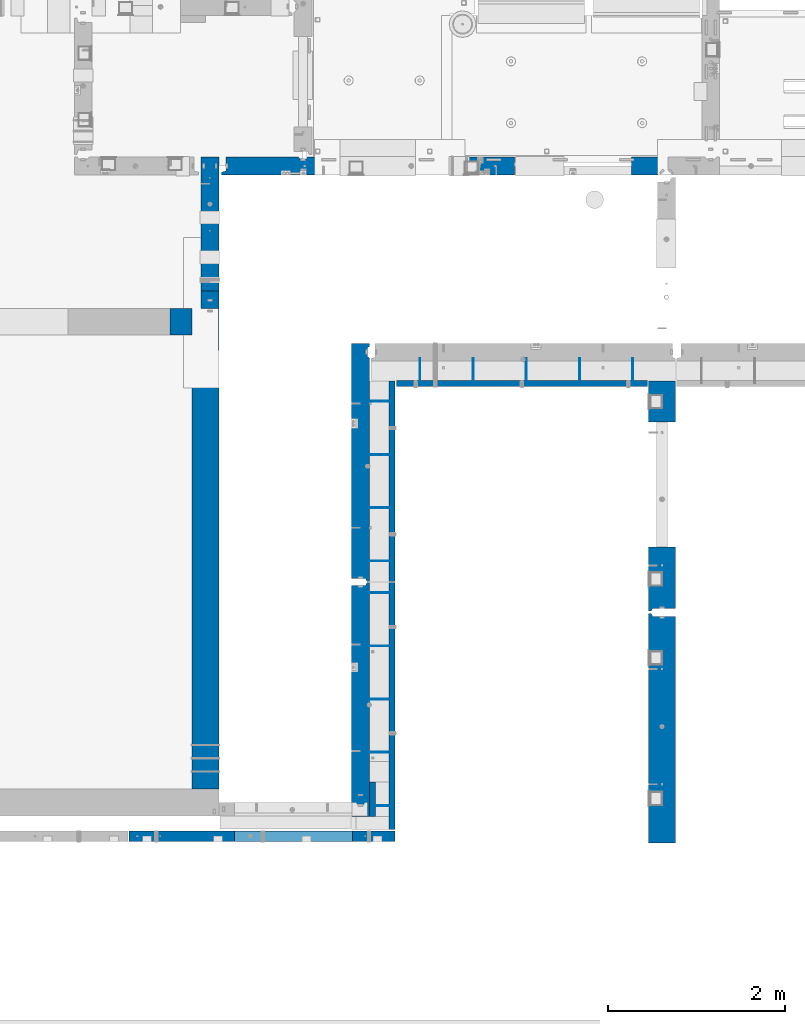
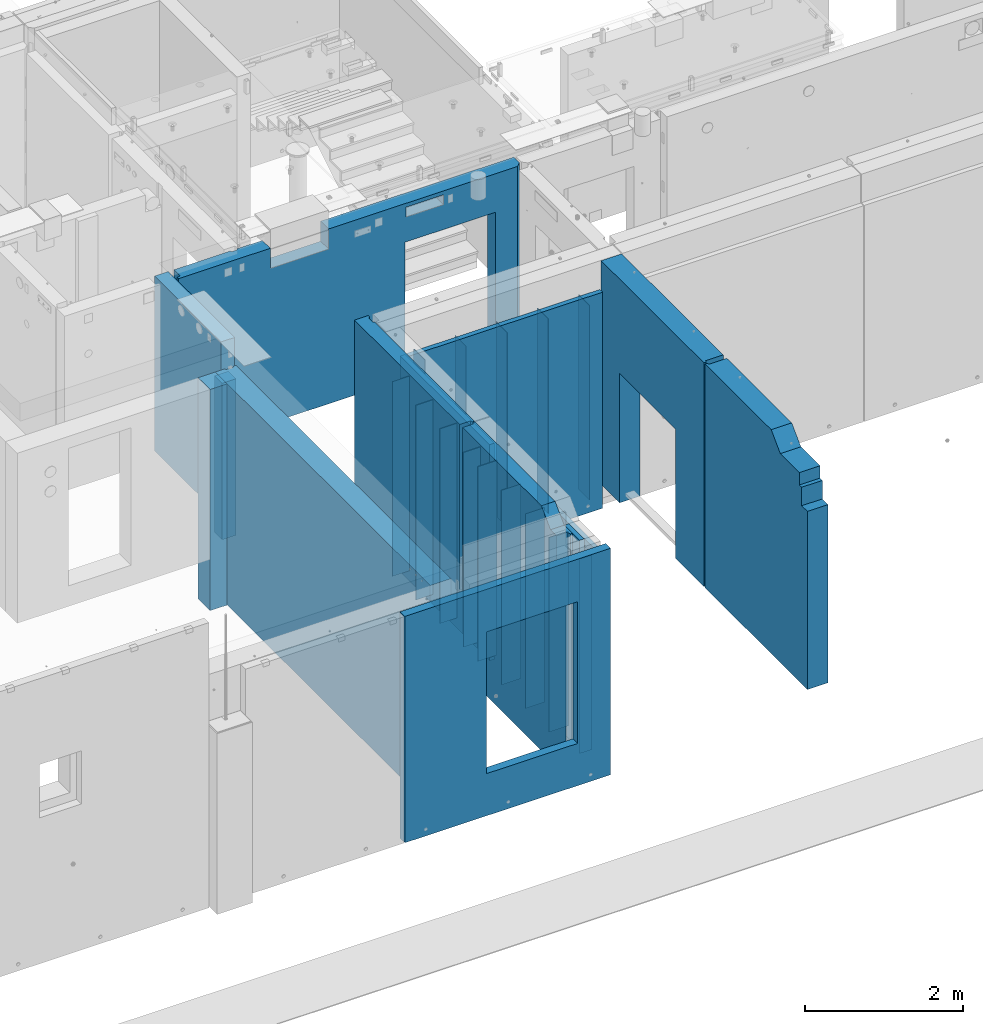
# One storey, part 171 of 264: 28 walls, 9 elements without a shape of their own.
"""IFC2X3 building model written with IfcOpenShell, lengths in millimetres."""

import ifcopenshell
import ifcopenshell.guid

model = None  # the IFC model being written
_history = None  # IfcOwnerHistory: only IFC2X3 demands one
_inside = {}  # id of a spatial element -> (the spatial element, [elements in it])
_under = {}  # id of a project, library or spatial element -> (it, [spatial elements below it])
_declared = {}  # id of a project -> (the project, [libraries it declares])
_typed = {}  # id of a type object -> (the type object, [elements of that type])
_made_of = {}  # id of a material, layer set ... -> (it, [elements and type objects made of it])


def new_model(schema):
    """Start an empty IFC model of exactly this schema.

    Asked for "IFC4X3", IfcOpenShell would pick the latest addendum, in which some entities
    have other attributes; the version numbers below select the first issue.
    IFC2X3 requires an IfcOwnerHistory on every rooted entity: one is made here for all.
    """
    global model, _history
    if schema == "IFC4X3":
        model = ifcopenshell.file(schema_version=(4, 3, 0, 0))
    else:
        model = ifcopenshell.file(schema=schema)
    _inside.clear()
    _under.clear()
    _declared.clear()
    _typed.clear()
    _made_of.clear()
    _history = None
    if model.schema == "IFC2X3":
        org = make("IfcOrganization", Name="unknown")
        user = make(
            "IfcPersonAndOrganization",
            ThePerson=make("IfcPerson", FamilyName="unknown"),
            TheOrganization=org,
        )
        app = make(
            "IfcApplication",
            ApplicationDeveloper=org,
            Version="unknown",
            ApplicationFullName="unknown",
            ApplicationIdentifier="unknown",
        )
        _history = make(
            "IfcOwnerHistory",
            OwningUser=user,
            OwningApplication=app,
            ChangeAction="ADDED",
            CreationDate=0,
        )
    return model


def make(cls, **values):
    """One entity of the class cls with the attributes given. An attribute that is None is left unset."""
    return model.create_entity(
        cls, **{name: value for name, value in values.items() if value is not None}
    )


def rooted(cls, **values):
    """An entity with a GlobalId (a new one), such as an element, a storey or a relation."""
    return make(cls, GlobalId=ifcopenshell.guid.new(), OwnerHistory=_history, **values)


def si_unit(unit_type, name, prefix=None):
    """IfcSIUnit, for example si_unit("LENGTHUNIT", "METRE", prefix="MILLI")."""
    return make("IfcSIUnit", UnitType=unit_type, Prefix=prefix, Name=name)


def assignment(units):
    """IfcUnitAssignment: the units of a project."""
    return None if units is None else make("IfcUnitAssignment", Units=units)


def point(xyz):
    """IfcCartesianPoint."""
    return None if xyz is None else make("IfcCartesianPoint", Coordinates=xyz)


def direction(xyz):
    """IfcDirection."""
    return None if xyz is None else make("IfcDirection", DirectionRatios=xyz)


def frame(location, z_axis=None, x_axis=None):
    """IfcAxis2Placement3D, a coordinate frame: its origin and axes. An axis left out is left unset."""
    return make(
        "IfcAxis2Placement3D",
        Location=point(location),
        Axis=direction(z_axis),
        RefDirection=direction(x_axis),
    )


def origin_with_axes():
    """The frame at (0, 0, 0) with the z axis (0, 0, 1) and the x axis (1, 0, 0) written out."""
    return frame((0.0, 0.0, 0.0), z_axis=(0.0, 0.0, 1.0), x_axis=(1.0, 0.0, 0.0))


def place(relative_to, where):
    """IfcLocalPlacement: puts the frame where relative to a parent placement (None: the world)."""
    return make(
        "IfcLocalPlacement", PlacementRelTo=relative_to, RelativePlacement=where
    )


def context(
    kind, dimensions, precision=None, world=None, true_north=None, identifier=None
):
    """IfcGeometricRepresentationContext, for example the 3D "Model" context."""
    return make(
        "IfcGeometricRepresentationContext",
        ContextIdentifier=identifier,
        ContextType=kind,
        CoordinateSpaceDimension=dimensions,
        Precision=precision,
        WorldCoordinateSystem=world,
        TrueNorth=true_north,
    )


def subcontext(parent, identifier, kind, view, scale=None):
    """IfcGeometricRepresentationSubContext, for example "Body" below "Model"."""
    return make(
        "IfcGeometricRepresentationSubContext",
        ContextIdentifier=identifier,
        ContextType=kind,
        ParentContext=parent,
        TargetScale=scale,
        TargetView=view,
    )


def project(units=None, contexts=None):
    """IfcProject with its units and contexts."""
    return rooted(
        "IfcProject",
        Name="project",
        RepresentationContexts=contexts,
        UnitsInContext=assignment(units),
    )


def spatial(cls, under=None, at=None, **own):
    """A site, building, storey or space (cls), placed at a placement, below another one or the project."""
    s = rooted(cls, ObjectPlacement=at, **own)
    if under is not None:
        _under.setdefault(under.id(), (under, []))[1].append(s)
    return s


def faces_of(points, faces, orient=None, outer=None):
    """IfcFace entities. A face is a list of loops; a loop is a list of indices into points, from 0.

    orient and outer hold one flag for each loop. By default every Orientation is true, the
    first loop of a face is its IfcFaceOuterBound and the others are IfcFaceBound.
    """
    made = []
    for i, loops in enumerate(faces):
        bounds = []
        for j, loop in enumerate(loops):
            is_outer = j == 0 if outer is None else outer[i][j]
            bounds.append(
                make(
                    "IfcFaceOuterBound" if is_outer else "IfcFaceBound",
                    Bound=make("IfcPolyLoop", Polygon=[points[k] for k in loop]),
                    Orientation=True if orient is None else orient[i][j],
                )
            )
        made.append(make("IfcFace", Bounds=bounds))
    return made


def faceted_brep(points, faces, orient=None, outer=None, voids=None):
    """IfcFacetedBrep: a solid bounded by flat faces; with voids (closed shells), ...WithVoids."""
    shared = [point(p) for p in points]
    hull = make("IfcClosedShell", CfsFaces=faces_of(shared, faces, orient, outer))
    if voids is None:
        return make("IfcFacetedBrep", Outer=hull)
    return make(
        "IfcFacetedBrepWithVoids",
        Outer=hull,
        Voids=[
            make(cls, CfsFaces=faces_of(shared, fs, o, b)) for cls, fs, o, b in voids
        ],
    )


def shape(context_of_items, identifier, shape_type, items):
    """IfcShapeRepresentation: the items that make up one representation, for example the "Body"."""
    return make(
        "IfcShapeRepresentation",
        ContextOfItems=context_of_items,
        RepresentationIdentifier=identifier,
        RepresentationType=shape_type,
        Items=items,
    )


def material(Name=None, Category=None):
    """IfcMaterial."""
    return make("IfcMaterial", Name=Name, Category=Category)


def made_of(thing, what):
    """Note that an element or type object is made of a material, layer set ...; save() writes the relation."""
    if what is not None:
        _made_of.setdefault(what.id(), (what, []))[1].append(thing)
    return thing


def type_object(cls, material=None, **own):
    """A type object (cls), such as IfcWallType, which elements share."""
    return made_of(rooted(cls, **own), material)


def element(
    cls,
    number,
    at=None,
    inside=None,
    cuts=None,
    type_object=None,
    material=None,
    context=None,
    identifier="Body",
    shape_type=None,
    held_by="IfcProductDefinitionShape",
    body=None,
    shapes=None,
    **own,
):
    """One element of the class cls, such as IfcWall. Its Tag is "e" and its number.

    at: its placement. inside: the storey or other place that contains it. cuts: it is an
    opening in that element (IfcRelVoidsElement). A single representation is given by context,
    identifier, shape_type and body (its items); several are given by shapes. held_by: the class
    of the entity that holds the representations. save() writes the other relations.
    """
    e = rooted(cls, Tag="e%d" % number, ObjectPlacement=at, **own)
    if body is not None:
        shapes = [shape(context, identifier, shape_type, body)]
    if shapes is not None:
        e.Representation = make(held_by, Representations=shapes)
    if inside is not None:
        _inside.setdefault(inside.id(), (inside, []))[1].append(e)
    if cuts is not None:
        rooted(
            "IfcRelVoidsElement", RelatingBuildingElement=cuts, RelatedOpeningElement=e
        )
    if type_object is not None:
        _typed.setdefault(type_object.id(), (type_object, []))[1].append(e)
    return made_of(e, material)


def aggregate(whole, parts):
    """IfcRelAggregates: a whole, such as a stair, and the parts it consists of."""
    return rooted("IfcRelAggregates", RelatingObject=whole, RelatedObjects=parts)


def save(model, path):
    """Write the relations noted so far, then the file.

    IfcRelAggregates (storeys below a building ...), IfcRelContainedInSpatialStructure (elements
    in a storey), IfcRelDefinesByType, IfcRelAssociatesMaterial and IfcRelDeclares: one each for
    every whole, place, type object, material and project.
    """
    for whole, parts in _under.values():
        aggregate(whole, parts)
    for where, things in _inside.values():
        rooted(
            "IfcRelContainedInSpatialStructure",
            RelatedElements=things,
            RelatingStructure=where,
        )
    for kind, things in _typed.values():
        rooted("IfcRelDefinesByType", RelatedObjects=things, RelatingType=kind)
    for what, things in _made_of.values():
        rooted("IfcRelAssociatesMaterial", RelatedObjects=things, RelatingMaterial=what)
    for by, libraries in _declared.values():
        rooted("IfcRelDeclares", RelatingContext=by, RelatedDefinitions=libraries)
    model.write(path)


model = new_model("IFC2X3")

# Units and contexts
model_context = context("Model", 3, precision=1e-05, world=origin_with_axes())
body_context = subcontext(model_context, "Body", "Model", "MODEL_VIEW")
ifc_project = project(units=[si_unit("LENGTHUNIT", "METRE", prefix="MILLI"), si_unit("AREAUNIT", "SQUARE_METRE"), si_unit("VOLUMEUNIT", "CUBIC_METRE"), si_unit("MASSUNIT", "GRAM", prefix="KILO"), si_unit("TIMEUNIT", "SECOND"), si_unit("PLANEANGLEUNIT", "RADIAN"), si_unit("SOLIDANGLEUNIT", "STERADIAN"), si_unit("THERMODYNAMICTEMPERATUREUNIT", "DEGREE_CELSIUS"), si_unit("LUMINOUSINTENSITYUNIT", "LUMEN")], contexts=[model_context])

# Site, building, storey
site_placement = place(None, origin_with_axes())
site = spatial("IfcSite", under=ifc_project, at=site_placement, CompositionType="ELEMENT")
building_placement = place(site_placement, origin_with_axes())
building = spatial("IfcBuilding", under=site, at=building_placement, CompositionType="ELEMENT")
storey_placement = place(building_placement, origin_with_axes())
storey = spatial("IfcBuildingStorey", under=building, at=storey_placement, Name="K", CompositionType="ELEMENT", Elevation=0.0)

# Assembly, wall
assembly_1_placement = place(storey_placement, origin_with_axes())
assembly_1 = element("IfcElementAssembly", 1, at=assembly_1_placement, inside=storey, AssemblyPlace="NOTDEFINED", PredefinedType="REINFORCEMENT_UNIT")
ifc_material_1 = material(Name="Undefined")
wall_type_1 = type_object("IfcWallType", PredefinedType="NOTDEFINED")
wall_1_placement = place(assembly_1_placement, frame((18710.0008459154, 7964.99567321541, 79360.0), z_axis=(0.0, 0.0, 1.0), x_axis=(-1.0, 3.00000001838171e-08, 0.0)))
wall_1 = element("IfcWall", 2, at=wall_1_placement, type_object=wall_type_1, material=ifc_material_1, Name="(PD)", context=body_context, shape_type="Brep", body=[
    faceted_brep([(0.0, 4.99999999999909, -1500.0), (0.0, 4.99999999999909, 1500.0), (180.000000000091, 4.99999999999909, 1500.0), (180.000000000091, 4.99999999999909, -1500.0), (0.0, -5.00000000000091, 1500.0), (180.000000000087, -5.00000000000091, 1500.0), (0.0, -5.00000000000091, -1500.0), (180.000000000087, -5.00000000000091, -1500.0)], [[[0, 1, 2, 3]], [[1, 4, 5, 2]], [[4, 6, 7, 5]], [[6, 0, 3, 7]], [[5, 7, 3, 2]], [[6, 4, 1, 0]]]),
])

# Assembly, walls
assembly_2_placement = place(storey_placement, origin_with_axes())
assembly_2 = element("IfcElementAssembly", 3, at=assembly_2_placement, inside=storey, AssemblyPlace="NOTDEFINED", PredefinedType="REINFORCEMENT_UNIT")
wall_2_placement = place(assembly_2_placement, frame((21429.9962229193, 12730.0010506694, 79360.0), z_axis=(0.0, 0.0, 1.0), x_axis=(0.0, 1.0, 0.0)))
wall_2 = element("IfcWall", 4, at=wall_2_placement, type_object=wall_type_1, material=ifc_material_1, Name="(PD)", context=body_context, shape_type="Brep", body=[
    faceted_brep([(0.0, 4.99999999999909, -1500.0), (0.0, 4.99999999999909, 1500.0), (280.000000000024, 5.0, 1500.0), (280.000000000024, 5.0, -1500.0), (0.0, -5.00000000000091, 1500.0), (280.000000000025, -5.0, 1500.0), (0.0, -5.00000000000091, -1500.0), (280.000000000025, -5.0, -1500.0)], [[[0, 1, 2, 3]], [[1, 4, 5, 2]], [[4, 6, 7, 5]], [[6, 0, 3, 7]], [[5, 7, 3, 2]], [[6, 4, 1, 0]]]),
])
wall_3_placement = place(assembly_2_placement, frame((20829.9962229193, 12730.0010506694, 79360.0), z_axis=(0.0, 0.0, 1.0), x_axis=(0.0, 1.0, 0.0)))
wall_3 = element("IfcWall", 5, at=wall_3_placement, type_object=wall_type_1, material=ifc_material_1, Name="(PD)", context=body_context, shape_type="Brep", body=[
    faceted_brep([(0.0, 4.99999999999909, -1500.0), (0.0, 4.99999999999909, 1500.0), (280.000000000024, 5.0, 1500.0), (280.000000000024, 5.0, -1500.0), (0.0, -5.00000000000091, 1500.0), (280.000000000025, -5.0, 1500.0), (0.0, -5.00000000000091, -1500.0), (280.000000000025, -5.0, -1500.0)], [[[0, 1, 2, 3]], [[1, 4, 5, 2]], [[4, 6, 7, 5]], [[6, 0, 3, 7]], [[5, 7, 3, 2]], [[6, 4, 1, 0]]]),
])
wall_4_placement = place(assembly_2_placement, frame((20229.9962229193, 12730.0010506694, 79360.0), z_axis=(0.0, 0.0, 1.0), x_axis=(0.0, 1.0, 0.0)))
wall_4 = element("IfcWall", 6, at=wall_4_placement, type_object=wall_type_1, material=ifc_material_1, Name="(PD)", context=body_context, shape_type="Brep", body=[
    faceted_brep([(0.0, 4.99999999999909, -1500.0), (0.0, 4.99999999999909, 1500.0), (280.000000000024, 5.0, 1500.0), (280.000000000024, 5.0, -1500.0), (0.0, -5.00000000000091, 1500.0), (280.000000000025, -5.0, 1500.0), (0.0, -5.00000000000091, -1500.0), (280.000000000025, -5.0, -1500.0)], [[[0, 1, 2, 3]], [[1, 4, 5, 2]], [[4, 6, 7, 5]], [[6, 0, 3, 7]], [[5, 7, 3, 2]], [[6, 4, 1, 0]]]),
])
wall_5_placement = place(assembly_2_placement, frame((19629.9962229193, 12730.0010506694, 79360.0), z_axis=(0.0, 0.0, 1.0), x_axis=(0.0, 1.0, 0.0)))
wall_5 = element("IfcWall", 7, at=wall_5_placement, type_object=wall_type_1, material=ifc_material_1, Name="(PD)", context=body_context, shape_type="Brep", body=[
    faceted_brep([(0.0, 4.99999999999909, -1500.0), (0.0, 4.99999999999909, 1500.0), (280.000000000024, 5.0, 1500.0), (280.000000000024, 5.0, -1500.0), (0.0, -5.00000000000091, 1500.0), (280.000000000025, -5.0, 1500.0), (0.0, -5.00000000000091, -1500.0), (280.000000000025, -5.0, -1500.0)], [[[0, 1, 2, 3]], [[1, 4, 5, 2]], [[4, 6, 7, 5]], [[6, 0, 3, 7]], [[5, 7, 3, 2]], [[6, 4, 1, 0]]]),
])

# Wall
wall_6_placement = place(assembly_1_placement, frame((18710.0008459154, 8564.99566219034, 79360.0), z_axis=(0.0, 0.0, 1.0), x_axis=(-1.0, 3.00000001838171e-08, 0.0)))
wall_6 = element("IfcWall", 8, at=wall_6_placement, type_object=wall_type_1, material=ifc_material_1, Name="(PD)", context=body_context, shape_type="Brep", body=[
    faceted_brep([(0.0, 4.99999999999909, -1500.0), (0.0, 4.99999999999909, 1500.0), (280.000000000024, 5.0, 1500.0), (280.000000000024, 5.0, -1500.0), (0.0, -5.00000000000091, 1500.0), (280.000000000025, -5.0, 1500.0), (0.0, -5.00000000000091, -1500.0), (280.000000000025, -5.0, -1500.0)], [[[0, 1, 2, 3]], [[1, 4, 5, 2]], [[4, 6, 7, 5]], [[6, 0, 3, 7]], [[5, 7, 3, 2]], [[6, 4, 1, 0]]]),
])

wall_7_placement = place(assembly_1_placement, frame((18710.0008459154, 9164.99566219034, 79360.0), z_axis=(0.0, 0.0, 1.0), x_axis=(-1.0, 3.00000001838171e-08, 0.0)))
wall_7 = element("IfcWall", 9, at=wall_7_placement, type_object=wall_type_1, material=ifc_material_1, Name="(PD)", context=body_context, shape_type="Brep", body=[
    faceted_brep([(0.0, 4.99999999999909, -1500.0), (0.0, 4.99999999999909, 1500.0), (280.000000000024, 5.0, 1500.0), (280.000000000024, 5.0, -1500.0), (0.0, -5.00000000000091, 1500.0), (280.000000000025, -5.0, 1500.0), (0.0, -5.00000000000091, -1500.0), (280.000000000025, -5.0, -1500.0)], [[[0, 1, 2, 3]], [[1, 4, 5, 2]], [[4, 6, 7, 5]], [[6, 0, 3, 7]], [[5, 7, 3, 2]], [[6, 4, 1, 0]]]),
])

wall_8_placement = place(assembly_1_placement, frame((18710.0008459154, 9764.99566219034, 79360.0), z_axis=(0.0, 0.0, 1.0), x_axis=(-1.0, 3.00000001838171e-08, 0.0)))
wall_8 = element("IfcWall", 10, at=wall_8_placement, type_object=wall_type_1, material=ifc_material_1, Name="(PD)", context=body_context, shape_type="Brep", body=[
    faceted_brep([(0.0, 4.99999999999909, -1500.0), (0.0, 4.99999999999909, 1500.0), (280.000000000024, 5.0, 1500.0), (280.000000000024, 5.0, -1500.0), (0.0, -5.00000000000091, 1500.0), (280.000000000025, -5.0, 1500.0), (0.0, -5.00000000000091, -1500.0), (280.000000000025, -5.0, -1500.0)], [[[0, 1, 2, 3]], [[1, 4, 5, 2]], [[4, 6, 7, 5]], [[6, 0, 3, 7]], [[5, 7, 3, 2]], [[6, 4, 1, 0]]]),
])

wall_9_placement = place(assembly_1_placement, frame((18710.0008459154, 10364.9956621903, 79360.0), z_axis=(0.0, 0.0, 1.0), x_axis=(-1.0, 3.00000001838171e-08, 0.0)))
wall_9 = element("IfcWall", 11, at=wall_9_placement, type_object=wall_type_1, material=ifc_material_1, Name="(PD)", context=body_context, shape_type="Brep", body=[
    faceted_brep([(0.0, 4.99999999999909, -1500.0), (0.0, 4.99999999999909, 1500.0), (280.000000000024, 5.0, 1500.0), (280.000000000024, 5.0, -1500.0), (0.0, -5.00000000000091, 1500.0), (280.000000000025, -5.0, 1500.0), (0.0, -5.00000000000091, -1500.0), (280.000000000025, -5.0, -1500.0)], [[[0, 1, 2, 3]], [[1, 4, 5, 2]], [[4, 6, 7, 5]], [[6, 0, 3, 7]], [[5, 7, 3, 2]], [[6, 4, 1, 0]]]),
])

# Assembly, walls
assembly_3_placement = place(storey_placement, origin_with_axes())
assembly_3 = element("IfcElementAssembly", 12, at=assembly_3_placement, inside=storey, AssemblyPlace="NOTDEFINED", PredefinedType="REINFORCEMENT_UNIT")
wall_10_placement = place(assembly_3_placement, frame((18710.0008459154, 10725.0056621903, 79360.0), z_axis=(0.0, 0.0, 1.0), x_axis=(-1.0, 3.00000001838171e-08, 0.0)))
wall_10 = element("IfcWall", 13, at=wall_10_placement, type_object=wall_type_1, material=ifc_material_1, Name="(PD)", context=body_context, shape_type="Brep", body=[
    faceted_brep([(0.0, 4.99999999999909, -1500.0), (0.0, 4.99999999999909, 1500.0), (280.000000000024, 5.0, 1500.0), (280.000000000024, 5.0, -1500.0), (0.0, -5.00000000000091, 1500.0), (280.000000000025, -5.0, 1500.0), (0.0, -5.00000000000091, -1500.0), (280.000000000025, -5.0, -1500.0)], [[[0, 1, 2, 3]], [[1, 4, 5, 2]], [[4, 6, 7, 5]], [[6, 0, 3, 7]], [[5, 7, 3, 2]], [[6, 4, 1, 0]]]),
])
wall_11_placement = place(assembly_3_placement, frame((18710.0008459154, 11325.0056621903, 79360.0), z_axis=(0.0, 0.0, 1.0), x_axis=(-1.0, 3.00000001838171e-08, 0.0)))
wall_11 = element("IfcWall", 14, at=wall_11_placement, type_object=wall_type_1, material=ifc_material_1, Name="(PD)", context=body_context, shape_type="Brep", body=[
    faceted_brep([(0.0, 4.99999999999909, -1500.0), (0.0, 4.99999999999909, 1500.0), (280.000000000024, 5.0, 1500.0), (280.000000000024, 5.0, -1500.0), (0.0, -5.00000000000091, 1500.0), (280.000000000025, -5.0, 1500.0), (0.0, -5.00000000000091, -1500.0), (280.000000000025, -5.0, -1500.0)], [[[0, 1, 2, 3]], [[1, 4, 5, 2]], [[4, 6, 7, 5]], [[6, 0, 3, 7]], [[5, 7, 3, 2]], [[6, 4, 1, 0]]]),
])
wall_12_placement = place(assembly_3_placement, frame((18710.0008459154, 11925.0056621903, 79360.0), z_axis=(0.0, 0.0, 1.0), x_axis=(-1.0, 3.00000001838171e-08, 0.0)))
wall_12 = element("IfcWall", 15, at=wall_12_placement, type_object=wall_type_1, material=ifc_material_1, Name="(PD)", context=body_context, shape_type="Brep", body=[
    faceted_brep([(0.0, 4.99999999999909, -1500.0), (0.0, 4.99999999999909, 1500.0), (280.000000000024, 5.0, 1500.0), (280.000000000024, 5.0, -1500.0), (0.0, -5.00000000000091, 1500.0), (280.000000000025, -5.0, 1500.0), (0.0, -5.00000000000091, -1500.0), (280.000000000025, -5.0, -1500.0)], [[[0, 1, 2, 3]], [[1, 4, 5, 2]], [[4, 6, 7, 5]], [[6, 0, 3, 7]], [[5, 7, 3, 2]], [[6, 4, 1, 0]]]),
])
wall_13_placement = place(assembly_3_placement, frame((18710.0008459154, 12525.0056621903, 79360.0), z_axis=(0.0, 0.0, 1.0), x_axis=(-1.0, 3.00000001838171e-08, 0.0)))
wall_13 = element("IfcWall", 16, at=wall_13_placement, type_object=wall_type_1, material=ifc_material_1, Name="(PD)", context=body_context, shape_type="Brep", body=[
    faceted_brep([(0.0, 4.99999999999909, -1500.0), (0.0, 4.99999999999909, 1500.0), (280.000000000024, 5.0, 1500.0), (280.000000000024, 5.0, -1500.0), (0.0, -5.00000000000091, 1500.0), (280.000000000025, -5.0, 1500.0), (0.0, -5.00000000000091, -1500.0), (280.000000000025, -5.0, -1500.0)], [[[0, 1, 2, 3]], [[1, 4, 5, 2]], [[4, 6, 7, 5]], [[6, 0, 3, 7]], [[5, 7, 3, 2]], [[6, 4, 1, 0]]]),
])

# Wall
wall_14_placement = place(assembly_2_placement, frame((19029.9962229193, 12730.0010506694, 79360.0), z_axis=(0.0, 0.0, 1.0), x_axis=(0.0, 1.0, 0.0)))
wall_14 = element("IfcWall", 17, at=wall_14_placement, type_object=wall_type_1, material=ifc_material_1, Name="(PD)", context=body_context, shape_type="Brep", body=[
    faceted_brep([(0.0, 4.99999999999909, -1500.0), (0.0, 4.99999999999909, 1500.0), (280.000000000024, 5.0, 1500.0), (280.000000000024, 5.0, -1500.0), (0.0, -5.00000000000091, 1500.0), (280.000000000025, -5.0, 1500.0), (0.0, -5.00000000000091, -1500.0), (280.000000000025, -5.0, -1500.0)], [[[0, 1, 2, 3]], [[1, 4, 5, 2]], [[4, 6, 7, 5]], [[6, 0, 3, 7]], [[5, 7, 3, 2]], [[6, 4, 1, 0]]]),
])

ifc_material_2 = material(Name="CONCRETE/C30/37")
wall_type_2 = type_object("IfcWallType", PredefinedType="NOTDEFINED")
wall_15_placement = place(assembly_1_placement, frame((18495.0, 8229.99983252054, 79520.0), z_axis=(0.0, 0.0, 1.0), x_axis=(0.0, -1.0, 0.0)))
wall_15 = element("IfcWall", 18, at=wall_15_placement, type_object=wall_type_2, material=ifc_material_2, context=body_context, shape_type="Brep", body=[
    faceted_brep([(0.0, 35.0, -1720.0), (0.0, 35.0, 1720.0), (384.999832520542, 35.0, 1720.0), (384.999832520542, 35.0, -1720.0), (0.0, -35.0, 1720.0), (384.999832520542, -35.0, 1720.0), (0.0, -35.0, -1720.0), (384.999832520542, -35.0, -1720.0)], [[[0, 1, 2, 3]], [[1, 4, 5, 2]], [[4, 6, 7, 5]], [[6, 0, 3, 7]], [[5, 7, 3, 2]], [[6, 4, 1, 0]]]),
])

# Assembly, wall
assembly_4_placement = place(storey_placement, origin_with_axes())
assembly_4 = element("IfcElementAssembly", 19, at=assembly_4_placement, inside=storey, AssemblyPlace="NOTDEFINED", PredefinedType="REINFORCEMENT_UNIT")
ifc_material_3 = material(Name="CONCRETE/C40/50")
wall_type_3 = type_object("IfcWallType", PredefinedType="NOTDEFINED")
wall_16_placement = place(assembly_4_placement, frame((18750.0, 7620.0, 79445.0), z_axis=(0.0, 0.0, 1.0), x_axis=(-1.0, 3.00000001838171e-08, 0.0)))
wall_16 = element("IfcWall", 20, at=wall_16_placement, type_object=wall_type_3, material=ifc_material_3, context=body_context, shape_type="Brep", body=[
    faceted_brep([(1810.00007820813, -60.0, 1090.0), (1810.00007820813, 60.0, 1090.0), (1810.00007820813, 60.0, -1095.0), (1810.00007820813, -60.0, -1095.0), (480.000078208133, 60.0, -1095.0), (480.000078208133, -60.0, -1095.0), (480.000078208133, 60.0, 1090.0), (480.000078208133, -60.0, 1090.0), (0.0, -60.0, 1745.0), (0.0, -60.0, -1745.0), (3000.0, -60.0, -1745.0), (3000.0, -60.0, 1745.0), (0.0, 60.0, 1745.0), (3000.0, 60.0, 1745.0), (0.0, 60.0, -1745.0), (3000.0, 60.0, -1745.0)], [[[0, 1, 2, 3]], [[3, 2, 4, 5]], [[5, 4, 6, 7]], [[7, 6, 1, 0]], [[8, 9, 10, 11], [3, 5, 7, 0]], [[12, 8, 11, 13]], [[9, 8, 12, 14]], [[9, 14, 15, 10]], [[11, 10, 15, 13]], [[14, 12, 13, 15], [2, 1, 6, 4]]]),
])
aggregate(assembly_4, [wall_16])

assembly_5_placement = place(storey_placement, origin_with_axes())
assembly_5 = element("IfcElementAssembly", 21, at=assembly_5_placement, inside=storey, AssemblyPlace="NOTDEFINED", PredefinedType="REINFORCEMENT_UNIT")
wall_type_4 = type_object("IfcWallType", PredefinedType="NOTDEFINED")
wall_17_placement = place(assembly_5_placement, frame((21760.0, 10145.0, 79745.0), z_axis=(0.0, 0.0, 1.0), x_axis=(0.0, 1.0, 0.0)))
wall_17 = element("IfcWall", 22, at=wall_17_placement, type_object=wall_type_4, material=ifc_material_2, context=body_context, shape_type="Brep", body=[
    faceted_brep([(15.0, 120.0, 1725.0), (15.0, 120.0, -1725.0), (45.0, 107.0, -1725.0), (45.0, 107.0, 1725.0), (45.0, -150.0, 1725.0), (45.0, -150.0, -1725.0), (734.999769628048, -150.0, -1725.0), (734.999769628048, 150.0, -1725.0), (734.999769628048, 150.0, 270.0), (734.999769628048, -150.0, 270.0), (2610.0, 150.0, -1725.0), (2610.0, -150.0, -1725.0), (2145.0, -150.0, -1725.0), (2145.0, 150.0, -1725.0), (2145.0, -150.0, 270.0), (2145.0, 150.0, 270.0), (15.0, 150.0, -1725.0), (15.0, 150.0, 1725.0), (2610.0, 150.0, 1725.0), (2610.0, -150.0, 1725.0)], [[[0, 1, 2, 3]], [[4, 3, 2, 5]], [[6, 7, 8, 9]], [[10, 11, 12, 13]], [[14, 15, 13, 12]], [[9, 8, 15, 14]], [[7, 16, 17, 18, 10, 13, 15, 8]], [[19, 11, 10, 18]], [[6, 9, 14, 12, 11, 19, 4, 5]], [[1, 16, 7, 6, 5, 2]], [[17, 16, 1, 0]], [[19, 18, 17, 0, 3, 4]]]),
])
aggregate(assembly_5, [wall_17])

assembly_6_placement = place(storey_placement, origin_with_axes())
assembly_6 = element("IfcElementAssembly", 23, at=assembly_6_placement, inside=storey, AssemblyPlace="NOTDEFINED", PredefinedType="REINFORCEMENT_UNIT")
wall_18_placement = place(assembly_6_placement, frame((21760.0, 7545.0, 79745.0), z_axis=(0.0, 0.0, 1.0), x_axis=(0.0, 1.0, 0.0)))
wall_18 = element("IfcWall", 24, at=wall_18_placement, type_object=wall_type_4, material=ifc_material_2, context=body_context, shape_type="Brep", body=[
    faceted_brep([(145.0, -150.0, 1020.0), (145.0, 150.0, 1020.0), (0.0, 150.0, 1020.0), (0.0, -150.0, 1020.0), (145.0, -150.0, 1305.0), (145.0, 150.0, 1305.0), (0.0, -150.0, -1725.0), (0.0, 150.0, -1725.0), (2585.0, 150.0, -1725.0), (2585.0, 119.999999999996, -1725.0), (2555.0, 107.0, -1725.0), (2555.0, -150.0, -1725.0), (2585.0, 150.0, 1725.0), (2585.0, 119.999999999996, 1725.0), (2555.0, 107.0, 1725.0), (2555.0, -150.0, 1725.0), (915.330322632846, 150.0, 1725.0), (915.330322632846, -150.0, 1725.0), (684.999832520542, 150.0, 1495.0), (684.999832520542, -150.0, 1495.0), (205.0, 150.0, 1495.0), (205.0, -150.0, 1495.0), (205.0, 150.0, 1305.0), (205.0, -150.0, 1305.0)], [[[0, 1, 2, 3]], [[4, 5, 1, 0]], [[6, 7, 8, 9, 10, 11]], [[8, 12, 13, 9]], [[14, 10, 9, 13]], [[15, 11, 10, 14]], [[13, 12, 16, 17, 15, 14]], [[17, 16, 18, 19]], [[19, 18, 20, 21]], [[21, 20, 22, 23]], [[3, 6, 11, 15, 17, 19, 21, 23, 4, 0]], [[7, 6, 3, 2]], [[22, 20, 18, 16, 12, 8, 7, 2, 1, 5]], [[23, 22, 5, 4]]]),
])
aggregate(assembly_6, [wall_18])

assembly_7_placement = place(storey_placement, origin_with_axes())
assembly_7 = element("IfcElementAssembly", 25, at=assembly_7_placement, inside=storey, AssemblyPlace="NOTDEFINED", PredefinedType="REINFORCEMENT_UNIT")
ifc_material_4 = material(Name="CONCRETE/Concrete_Undefined")
wall_type_5 = type_object("IfcWallType", PredefinedType="NOTDEFINED")
wall_19_placement = place(assembly_7_placement, frame((16660.0, 13575.0001037209, 79645.0), z_axis=(0.0, 0.0, 1.0), x_axis=(0.0, 1.0, 0.0)))
wall_19 = element("IfcWall", 26, at=wall_19_placement, type_object=wall_type_5, material=ifc_material_4, context=body_context, shape_type="Brep", body=[
    faceted_brep([(0.0, 100.0, -1205.0), (0.0, 100.0, 1205.0), (194.999961809157, 100.0, 1205.0), (194.999961809157, 100.0, -1205.0), (0.0, -100.0, 1205.0), (194.999961809157, -100.0, 1205.0), (0.0, -100.0, -1205.0), (194.999961809157, -100.0, -1205.0)], [[[0, 1, 2, 3]], [[1, 4, 5, 2]], [[4, 6, 7, 5]], [[6, 0, 3, 7]], [[5, 7, 3, 2]], [[6, 4, 1, 0]]]),
])

# Wall
wall_type_6 = type_object("IfcWallType", PredefinedType="NOTDEFINED")
wall_20_placement = place(assembly_1_placement, frame((18715.0, 10480.0018965848, 79365.0), z_axis=(0.0, 0.0, 1.0), x_axis=(0.0, -1.0, 0.0)))
wall_20 = element("IfcWall", 27, at=wall_20_placement, type_object=wall_type_6, material=ifc_material_2, context=body_context, shape_type="Brep", body=[
    faceted_brep([(0.0, 35.0, -1665.0), (0.0, 35.0, 1665.0), (2785.00189658477, 35.0, 1665.0), (2785.00189658477, 35.0, -1665.0), (0.0, -35.0, 1665.0), (2785.00189658477, -35.0, 1665.0), (0.0, -35.0, -1665.0), (2785.00189658477, -35.0, -1665.0)], [[[0, 1, 2, 3]], [[1, 4, 5, 2]], [[4, 6, 7, 5]], [[6, 0, 3, 7]], [[5, 7, 3, 2]], [[6, 4, 1, 0]]]),
])

wall_21_placement = place(assembly_3_placement, frame((18715.0, 12755.0018965848, 79365.0), z_axis=(0.0, 0.0, 1.0), x_axis=(0.0, -1.0, 0.0)))
wall_21 = element("IfcWall", 28, at=wall_21_placement, type_object=wall_type_6, material=ifc_material_2, context=body_context, shape_type="Brep", body=[
    faceted_brep([(0.0, 35.0, -1665.0), (0.0, 35.0, 1665.0), (2260.0, 35.0, 1665.0), (2260.0, 35.0, -1665.0), (0.0, -35.0, 1665.0), (2260.0, -35.0, 1665.0), (0.0, -35.0, -1665.0), (2260.0, -35.0, -1665.0)], [[[0, 1, 2, 3]], [[1, 4, 5, 2]], [[4, 6, 7, 5]], [[6, 0, 3, 7]], [[5, 7, 3, 2]], [[6, 4, 1, 0]]]),
])

wall_22_placement = place(assembly_2_placement, frame((21595.0, 12725.0018965848, 79365.0), z_axis=(0.0, 0.0, 1.0), x_axis=(-1.0, 3.00000001838171e-08, 0.0)))
wall_22 = element("IfcWall", 29, at=wall_22_placement, type_object=wall_type_6, material=ifc_material_2, context=body_context, shape_type="Brep", body=[
    faceted_brep([(2371.45898241561, -35.0, 4.56708580913255), (2371.45898241561, 35.0, 4.56708580913255), (2376.87830119873, 35.0, 12.6776695296576), (2376.87830119873, -35.0, 12.6776695296576), (2384.98888491927, 35.0, 18.0969883127837), (2384.98888491927, -35.0, 18.0969883127837), (2394.5559707284, 35.0, 20.0), (2394.5559707284, -35.0, 20.0), (2404.12305653753, 35.0, 18.0969883127837), (2404.12305653753, -35.0, 18.0969883127837), (2412.23364025806, 35.0, 12.6776695296576), (2412.23364025806, -35.0, 12.6776695296576), (2417.65295904118, 35.0, 4.56708580913255), (2417.65295904118, -35.0, 4.56708580913255), (2419.5559707284, 35.0, -5.0), (2419.5559707284, -35.0, -5.0), (2417.65295904118, 35.0, -14.5670858091326), (2417.65295904118, -35.0, -14.5670858091326), (2412.23364025806, 35.0, -22.6776695296576), (2412.23364025806, -35.0, -22.6776695296576), (2404.12305653753, 35.0, -28.0969883127837), (2404.12305653753, -35.0, -28.0969883127837), (2394.5559707284, 35.0, -30.0), (2394.5559707284, -35.0, -30.0), (2384.98888491927, 35.0, -28.0969883127837), (2384.98888491927, -35.0, -28.0969883127837), (2376.87830119873, 35.0, -22.6776695296576), (2376.87830119873, -35.0, -22.6776695296576), (2371.45898241561, 35.0, -14.5670858091326), (2371.45898241561, -35.0, -14.5670858091326), (2369.5559707284, 35.0, -5.0), (2369.5559707284, -35.0, -5.0), (0.0, -35.0, 1665.0), (0.0, -35.0, -1665.0), (2830.0, -35.0, -1665.0), (2830.0, -35.0, 1665.0), (0.0, 35.0, 1665.0), (2830.0, 35.0, 1665.0), (0.0, 35.0, -1665.0), (2830.0, 35.0, -1665.0)], [[[0, 1, 2, 3]], [[3, 2, 4, 5]], [[5, 4, 6, 7]], [[7, 6, 8, 9]], [[9, 8, 10, 11]], [[11, 10, 12, 13]], [[13, 12, 14, 15]], [[15, 14, 16, 17]], [[17, 16, 18, 19]], [[19, 18, 20, 21]], [[21, 20, 22, 23]], [[23, 22, 24, 25]], [[25, 24, 26, 27]], [[27, 26, 28, 29]], [[29, 28, 30, 31]], [[31, 30, 1, 0]], [[32, 33, 34, 35], [3, 5, 7, 9, 11, 13, 15, 17, 19, 21, 23, 25, 27, 29, 31, 0]], [[36, 32, 35, 37]], [[33, 32, 36, 38]], [[33, 38, 39, 34]], [[35, 34, 39, 37]], [[38, 36, 37, 39], [26, 24, 22, 20, 18, 16, 14, 12, 10, 8, 6, 4, 2, 1, 30, 28]]]),
])

aggregate(assembly_2, [wall_2, wall_3, wall_4, wall_5, wall_14, wall_22])

wall_type_7 = type_object("IfcWallType", PredefinedType="NOTDEFINED")
wall_23_placement = place(assembly_7_placement, frame((16210.0003210833, 13425.0000655301, 79355.0), z_axis=(0.0, 0.0, 1.0), x_axis=(1.0, 0.0, 0.0)))
wall_23 = element("IfcWall", 30, at=wall_23_placement, type_object=wall_type_7, material=ifc_material_4, context=body_context, shape_type="Brep", body=[
    faceted_brep([(0.0, 150.0, -1705.0), (0.0, 150.0, 1705.0), (250.000610351563, 150.0, 1705.0), (250.000610351563, 150.0, -1705.0), (0.0, -150.0, 1705.0), (250.000610351563, -150.0, 1705.0), (0.0, -150.0, -1705.0), (250.000610351563, -150.0, -1705.0)], [[[0, 1, 2, 3]], [[1, 4, 5, 2]], [[4, 6, 7, 5]], [[6, 0, 3, 7]], [[5, 7, 3, 2]], [[6, 4, 1, 0]]]),
])

wall_24_placement = place(assembly_7_placement, frame((16610.0009314348, 8149.99701377227, 79355.0), z_axis=(0.0, 0.0, 1.0), x_axis=(0.0, 1.0, 0.0)))
wall_24 = element("IfcWall", 31, at=wall_24_placement, type_object=wall_type_7, material=ifc_material_4, context=body_context, shape_type="Brep", body=[
    faceted_brep([(5425.00305175781, 15.0009109737621, 1495.0), (5405.0030832364, 2.00093143484628, 1495.0), (5405.0030832364, -101.999068565154, 1495.0), (5425.00305175781, -114.99904810407, 1495.0), (5405.0030832364, 2.00093143484628, 1705.0), (5425.00305175781, 15.0009109737621, 1705.0), (5405.0030832364, -101.999068565154, 1705.0), (5425.00305175781, -114.99904810407, 1705.0), (0.0, -150.0, -1705.0), (0.0, 150.0, -1705.0), (5425.00305175781, 150.0, -1705.0), (5425.00305175781, -150.0, -1705.0), (0.0, -150.0, 1705.0), (0.0, 150.0, 1705.0), (500.003099178535, -150.0, 1665.0), (500.003099178535, 150.0, 1665.0), (507.0741669904, 150.0, 1662.07106781186), (507.0741669904, -150.0, 1662.07106781186), (492.93203136667, -150.0, 1662.07106781186), (492.93203136667, 150.0, 1662.07106781186), (490.003099178535, -150.0, 1655.0), (490.003099178535, 150.0, 1655.0), (492.93203136667, -150.0, 1647.92893218814), (492.93203136667, 150.0, 1647.92893218814), (500.003099178535, -150.0, 1645.0), (500.003099178535, 150.0, 1645.0), (507.0741669904, -150.0, 1647.92893218814), (507.0741669904, 150.0, 1647.92893218814), (510.003099178535, -150.0, 1655.0), (510.003099178535, 150.0, 1655.0), (350.003099178535, -150.0, 1665.0), (350.003099178535, 150.0, 1665.0), (357.0741669904, 150.0, 1662.07106781186), (357.0741669904, -150.0, 1662.07106781186), (342.93203136667, -150.0, 1662.07106781186), (342.93203136667, 150.0, 1662.07106781186), (340.003099178535, -150.0, 1655.0), (340.003099178535, 150.0, 1655.0), (342.93203136667, -150.0, 1647.92893218814), (342.93203136667, 150.0, 1647.92893218814), (350.003099178535, -150.0, 1645.0), (350.003099178535, 150.0, 1645.0), (357.0741669904, -150.0, 1647.92893218814), (357.0741669904, 150.0, 1647.92893218814), (360.003099178535, -150.0, 1655.0), (360.003099178535, 150.0, 1655.0), (5425.00305175781, 150.0, 1705.0), (200.003099178535, 150.0, 1665.0), (192.93203136667, 150.0, 1662.07106781186), (190.003099178535, 150.0, 1655.0), (192.93203136667, 150.0, 1647.92893218814), (200.003099178535, 150.0, 1645.0), (207.0741669904, 150.0, 1647.92893218814), (210.003099178535, 150.0, 1655.0), (207.0741669904, 150.0, 1662.07106781186), (207.0741669904, -150.0, 1662.07106781186), (210.003099178535, -150.0, 1655.0), (200.003099178535, -150.0, 1665.0), (192.93203136667, -150.0, 1662.07106781186), (190.003099178535, -150.0, 1655.0), (192.93203136667, -150.0, 1647.92893218814), (200.003099178535, -150.0, 1645.0), (207.0741669904, -150.0, 1647.92893218814), (5425.00305175781, -150.0, 1705.0)], [[[0, 1, 2, 3]], [[4, 1, 0, 5]], [[6, 2, 1, 4]], [[7, 3, 2, 6]], [[8, 9, 10, 11]], [[8, 12, 13, 9]], [[14, 15, 16, 17]], [[18, 19, 15, 14]], [[20, 21, 19, 18]], [[22, 23, 21, 20]], [[24, 25, 23, 22]], [[26, 27, 25, 24]], [[28, 29, 27, 26]], [[17, 16, 29, 28]], [[30, 31, 32, 33]], [[34, 35, 31, 30]], [[36, 37, 35, 34]], [[38, 39, 37, 36]], [[40, 41, 39, 38]], [[42, 43, 41, 40]], [[44, 45, 43, 42]], [[33, 32, 45, 44]], [[9, 13, 46, 10], [47, 48, 49, 50, 51, 52, 53, 54], [31, 35, 37, 39, 41, 43, 45, 32], [15, 19, 21, 23, 25, 27, 29, 16]], [[55, 54, 53, 56]], [[57, 47, 54, 55]], [[58, 48, 47, 57]], [[59, 49, 48, 58]], [[60, 50, 49, 59]], [[61, 51, 50, 60]], [[62, 52, 51, 61]], [[56, 53, 52, 62]], [[12, 8, 11, 63], [61, 60, 59, 58, 57, 55, 56, 62], [40, 38, 36, 34, 30, 33, 44, 42], [24, 22, 20, 18, 14, 17, 28, 26]], [[4, 5, 46, 13, 12, 63, 7, 6]], [[63, 11, 10, 46, 5, 0, 3, 7]]]),
])

aggregate(assembly_7, [wall_19, wall_23, wall_24])

# Assembly, wall
assembly_8_placement = place(storey_placement, origin_with_axes())
assembly_8 = element("IfcElementAssembly", 32, at=assembly_8_placement, inside=storey, AssemblyPlace="NOTDEFINED", PredefinedType="REINFORCEMENT_UNIT")
wall_type_8 = type_object("IfcWallType", PredefinedType="NOTDEFINED")
wall_25_placement = place(assembly_8_placement, frame((16789.9991455078, 15180.0, 80122.5), z_axis=(0.0, 0.0, 1.0), x_axis=(1.0, 0.0, 0.0)))
wall_25 = element("IfcWall", 33, at=wall_25_placement, type_object=wall_type_8, material=ifc_material_2, context=body_context, shape_type="Brep", body=[
    faceted_brep([(5005.00085449219, 100.0, -1347.5), (5005.00085449219, 100.0, 1347.5), (5005.00085449219, -40.0, 1347.5), (5005.00085449219, -40.0, -1347.5), (4945.00085449219, -100.0, 1347.5), (2190.00089114904, 100.0, 1347.5), (2190.00089114904, -100.0, 1347.5), (4945.00085449219, -100.0, -1347.5), (4625.00331180594, -100.0, -1347.5), (4625.00331180594, 100.0, -1347.5), (4625.00331180594, -100.0, 752.5), (4625.00331180594, 100.0, 752.5), (3304.99812381766, -100.0, 752.5), (3304.99812381766, 100.0, 752.5), (3304.99812381766, -100.0, -1347.5), (3304.99812381766, 100.0, -1347.5), (970.000854492188, 100.0, -1347.5), (970.000854492188, 100.0, 1347.5), (1340.00089114904, 100.0, 1347.5), (1340.00089114904, 100.000000000002, 1337.5), (1340.00089114904, 100.000000000002, 1037.5), (2190.00089114904, 100.000000000002, 1037.5), (2190.00089114904, 100.000000000002, 1337.5), (3314.65070010862, 100.000000000002, 1137.5), (3864.65070011262, 100.000000000002, 1137.5), (3864.65070011262, 100.000000000004, 1287.5), (3314.65070010862, 100.000000000004, 1287.5), (50.0008544921875, 100.0, 1347.5), (50.0008544921875, 100.0, -1347.5), (50.0008544921875, -57.0, -1347.5), (50.0008544921875, -57.0, 1347.5), (870.000854492191, 100.0, 1347.5), (870.000854492191, 100.0, -1347.5), (883.000854492188, 80.0, 1347.5), (883.000854492188, 80.0, -1347.5), (957.000854492188, 80.0, 1347.5), (957.000854492188, 80.0, -1347.5), (0.0, -100.0, -1347.5), (0.0, -70.0002221679679, -1347.5), (0.0, -70.0002221679679, 1347.5), (0.0, -100.0, 1347.5), (1340.00089114904, -100.0, 1347.5), (1340.00089114904, -100.0, 1337.5), (1340.00089114904, -100.0, 1037.5), (2190.00089114904, -100.0, 1037.5), (2190.00089114904, -100.0, 1337.5), (3314.65146310862, -100.0, 1137.5), (3314.65146310862, -100.0, 1287.5), (3864.65146311262, -100.0, 1287.5), (3864.65146311262, -100.0, 1137.5)], [[[0, 1, 2, 3]], [[4, 2, 1, 5, 6]], [[2, 4, 7, 3]], [[8, 9, 0, 3, 7]], [[9, 8, 10, 11]], [[11, 10, 12, 13]], [[13, 12, 14, 15]], [[1, 0, 9, 11, 13, 15, 16, 17, 18, 19, 20, 21, 22, 5], [23, 24, 25, 26]], [[27, 28, 29, 30]], [[28, 27, 31, 32]], [[33, 34, 32, 31]], [[35, 36, 34, 33]], [[17, 16, 36, 35]], [[15, 14, 37, 38, 29, 28, 32, 34, 36, 16]], [[30, 29, 38, 39]], [[37, 40, 39, 38]], [[17, 35, 33, 31, 27, 30, 39, 40, 41, 18]], [[18, 41, 42, 19]], [[19, 42, 43, 20]], [[20, 43, 44, 21]], [[21, 44, 45, 22]], [[5, 22, 45, 6]], [[44, 43, 42, 41, 40, 37, 14, 12, 10, 8, 7, 4, 6, 45], [46, 47, 48, 49]], [[25, 48, 47, 26]], [[24, 49, 48, 25]], [[23, 46, 49, 24]], [[26, 47, 46, 23]]]),
])
aggregate(assembly_8, [wall_25])

assembly_9_placement = place(storey_placement, origin_with_axes())
assembly_9 = element("IfcElementAssembly", 34, at=assembly_9_placement, inside=storey, AssemblyPlace="NOTDEFINED", PredefinedType="REINFORCEMENT_UNIT")
wall_26_placement = place(assembly_9_placement, frame((16660.0, 13575.0001284873, 80122.5), z_axis=(0.0, 0.0, 1.0), x_axis=(0.0, 1.0, 0.0)))
wall_26 = element("IfcWall", 35, at=wall_26_placement, type_object=wall_type_8, material=ifc_material_2, context=body_context, shape_type="Brep", body=[
    faceted_brep([(30.0, 100.0, -1347.5), (30.0, 100.0, 1347.5), (1704.99987151274, 100.0, 1347.5), (1704.99987151274, 100.0, -1347.5), (29.9999685214098, -100.0, 1347.5), (1704.99987151274, -100.0, 1347.5), (29.9999685214098, -100.0, -1347.5), (1704.99987151274, -100.0, -1347.5)], [[[0, 1, 2, 3]], [[1, 4, 5, 2]], [[4, 6, 7, 5]], [[6, 0, 3, 7]], [[5, 7, 3, 2]], [[6, 4, 1, 0]]]),
])
aggregate(assembly_9, [wall_26])

# Wall
wall_type_9 = type_object("IfcWallType", PredefinedType="NOTDEFINED")
wall_27_placement = place(assembly_1_placement, frame((18360.0, 10480.0018965848, 79585.0), z_axis=(0.0, 0.0, 1.0), x_axis=(0.0, -1.0, 0.0)))
wall_27 = element("IfcWall", 36, at=wall_27_placement, type_object=wall_type_9, material=ifc_material_2, context=body_context, shape_type="Brep", body=[
    faceted_brep([(2405.00189658477, -100.0, 1655.0), (2405.00189658477, -100.0, 925.029999999999), (2405.00189658477, 57.0, 925.029999999999), (2405.00189658477, 57.0, 1655.0), (2455.00189658477, 70.0, 925.0), (2455.00189658477, -100.0, 925.0), (2455.00189658477, 70.0, 1655.0), (2635.00189658477, -100.0, -1885.0), (2635.00189658477, 100.0, -1885.0), (2635.00189658477, 100.0, 925.0), (2635.00189658477, -100.0, 925.0), (0.0, 100.0, 1885.0), (0.0, 100.0, -1885.0), (0.0, 70.0, -1885.0), (0.0, 70.0, 1885.0), (30.0, 57.0, -1885.0), (30.0, 57.0, 1885.0), (30.0, -100.0, -1885.0), (30.0, -100.0, 1885.0), (2019.67157395192, -100.0, 1885.0), (2019.67157395192, 100.0, 1885.0), (2250.00206406423, -100.0, 1655.0), (2250.00206406423, 100.0, 1655.0), (2455.00189658477, 100.0, 1655.0), (2455.00189658477, 100.0, 925.0)], [[[0, 1, 2, 3]], [[4, 2, 1, 5]], [[6, 3, 2, 4]], [[7, 8, 9, 10]], [[11, 12, 13, 14]], [[14, 13, 15, 16]], [[12, 8, 7, 17, 15, 13]], [[16, 15, 17, 18]], [[11, 14, 16, 18, 19, 20]], [[20, 19, 21, 22]], [[9, 8, 12, 11, 20, 22, 23, 24]], [[24, 23, 6, 4]], [[10, 9, 24, 4, 5]], [[21, 19, 18, 17, 7, 10, 5, 1, 0]], [[23, 22, 21, 0, 3, 6]]]),
])

aggregate(assembly_1, [wall_1, wall_15, wall_6, wall_7, wall_8, wall_9, wall_20, wall_27])

ifc_material_5 = material(Name="CONCRETE/C25/30")
wall_28_placement = place(assembly_3_placement, frame((18360.0, 13180.0018965848, 79585.0), z_axis=(0.0, 0.0, 1.0), x_axis=(0.0, -1.0, 0.0)))
wall_28 = element("IfcWall", 37, at=wall_28_placement, type_object=wall_type_9, material=ifc_material_5, context=body_context, shape_type="Brep", body=[
    faceted_brep([(165.0, 100.0, 1885.0), (165.0, 100.0, -1885.0), (152.0, 80.0, -1885.0), (152.0, 80.0, 1885.0), (48.0, 80.0, -1885.0), (48.0, 80.0, 1885.0), (34.9999999999982, 100.0, 1885.0), (34.9999999999982, 100.0, -1885.0), (2685.0, 100.0, -1885.0), (2685.0, 100.0, 1885.0), (2685.0, 70.0000000000036, 1885.0), (2685.0, 70.0000000000036, -1885.0), (2655.0, 57.0, 1885.0), (2655.0, 57.0, -1885.0), (2655.0, -100.0, 1885.0), (2655.0, -100.0, -1885.0), (0.0, -100.0, 1885.0), (0.0, -100.0, -1885.0), (0.0, 100.0, 1885.0), (0.0, 100.0, -1885.0)], [[[0, 1, 2, 3]], [[3, 2, 4, 5]], [[6, 5, 4, 7]], [[8, 9, 10, 11]], [[10, 12, 13, 11]], [[14, 15, 13, 12]], [[16, 17, 15, 14]], [[17, 16, 18, 19]], [[19, 18, 6, 7]], [[2, 1, 8, 11, 13, 15, 17, 19, 7, 4]], [[9, 8, 1, 0]], [[18, 16, 14, 12, 10, 9, 0, 3, 5, 6]]]),
])

aggregate(assembly_3, [wall_10, wall_11, wall_12, wall_13, wall_21, wall_28])

save(model, "model.ifc")
